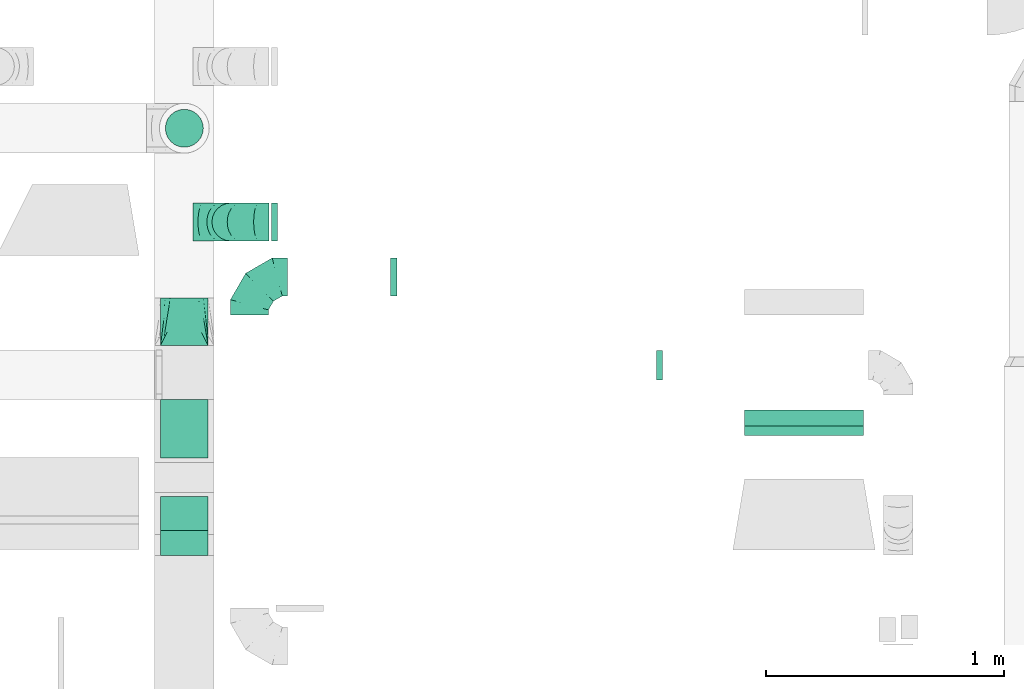
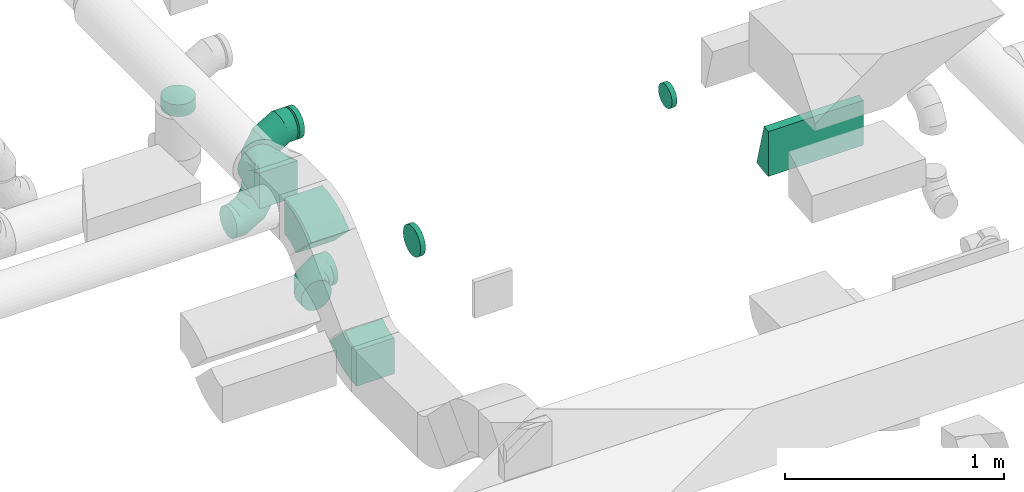
# One storey, part 42 of 62: 11 flow fittings.
"""IFC2X3 building model written with IfcOpenShell, lengths in millimetres."""

from ifc_helpers import new_model, entity, si_unit, converted_unit, derived_unit, direction, frame, frame_2d, origin, place, context, subcontext, project, spatial, polyline, circle_curve, parameter, trimmed, segment, composite_curve, outline, extrude, faceted_brep, source, transform, mapped, material, type_object, type_shapes, element, save


model = new_model("IFC2X3")

# Units and contexts
model_context = context("Model", 3, precision=0.01, world=origin(), true_north=direction((6.12303176911189e-17, 1.0)))
body_context = subcontext(model_context, "Body", "Model", "MODEL_VIEW")
ifc_project = project(units=[si_unit("LENGTHUNIT", "METRE", prefix="MILLI"), si_unit("AREAUNIT", "SQUARE_METRE"), si_unit("VOLUMEUNIT", "CUBIC_METRE"), converted_unit("PLANEANGLEUNIT", "DEGREE", entity("IfcRatioMeasure", 0.0174532925199433), si_unit("PLANEANGLEUNIT", "RADIAN"), dimensions=[0, 0, 0, 0, 0, 0, 0]), si_unit("MASSUNIT", "GRAM", prefix="KILO"), derived_unit("MASSDENSITYUNIT", [(si_unit("MASSUNIT", "GRAM", prefix="KILO"), 1), (si_unit("LENGTHUNIT", "METRE"), -3)]), derived_unit("MOMENTOFINERTIAUNIT", [(si_unit("LENGTHUNIT", "METRE"), 4)]), si_unit("TIMEUNIT", "SECOND"), si_unit("FREQUENCYUNIT", "HERTZ"), si_unit("THERMODYNAMICTEMPERATUREUNIT", "DEGREE_CELSIUS"), derived_unit("THERMALTRANSMITTANCEUNIT", [(si_unit("MASSUNIT", "GRAM", prefix="KILO"), 1), (si_unit("THERMODYNAMICTEMPERATUREUNIT", "KELVIN"), -1), (si_unit("TIMEUNIT", "SECOND"), -3)]), derived_unit("VOLUMETRICFLOWRATEUNIT", [(si_unit("LENGTHUNIT", "METRE"), 3), (si_unit("TIMEUNIT", "SECOND"), -1)]), derived_unit("MASSFLOWRATEUNIT", [(si_unit("MASSUNIT", "GRAM", prefix="KILO"), 1), (si_unit("TIMEUNIT", "SECOND"), -1)]), derived_unit("ROTATIONALFREQUENCYUNIT", [(si_unit("TIMEUNIT", "SECOND"), -1)]), si_unit("ELECTRICCURRENTUNIT", "AMPERE"), si_unit("ELECTRICVOLTAGEUNIT", "VOLT"), si_unit("POWERUNIT", "WATT"), si_unit("FORCEUNIT", "NEWTON", prefix="KILO"), si_unit("ILLUMINANCEUNIT", "LUX"), si_unit("LUMINOUSFLUXUNIT", "LUMEN"), si_unit("LUMINOUSINTENSITYUNIT", "CANDELA"), derived_unit("USERDEFINED", [(si_unit("MASSUNIT", "GRAM", prefix="KILO"), -1), (si_unit("LENGTHUNIT", "METRE"), -2), (si_unit("TIMEUNIT", "SECOND"), 3), (si_unit("LUMINOUSFLUXUNIT", "LUMEN"), 1)]), derived_unit("LINEARVELOCITYUNIT", [(si_unit("LENGTHUNIT", "METRE"), 1), (si_unit("TIMEUNIT", "SECOND"), -1)]), si_unit("PRESSUREUNIT", "PASCAL"), derived_unit("USERDEFINED", [(si_unit("LENGTHUNIT", "METRE"), -2), (si_unit("MASSUNIT", "GRAM", prefix="KILO"), 1), (si_unit("TIMEUNIT", "SECOND"), -2)]), derived_unit("LINEARFORCEUNIT", [(si_unit("MASSUNIT", "GRAM", prefix="KILO"), 1), (si_unit("LENGTHUNIT", "METRE"), 1), (si_unit("TIMEUNIT", "SECOND"), -2), (si_unit("LENGTHUNIT", "METRE"), -1)]), derived_unit("PLANARFORCEUNIT", [(si_unit("MASSUNIT", "GRAM", prefix="KILO"), 1), (si_unit("LENGTHUNIT", "METRE"), 1), (si_unit("TIMEUNIT", "SECOND"), -2), (si_unit("LENGTHUNIT", "METRE"), -2)])], contexts=[model_context])

# Site, building, storey
site_placement = place(None, origin())
site = spatial("IfcSite", under=ifc_project, at=site_placement, CompositionType="ELEMENT")
building_placement = place(site_placement, origin())
building = spatial("IfcBuilding", under=site, at=building_placement, CompositionType="ELEMENT")
storey_placement = place(building_placement, frame((0.0, 0.0, 24000.0)))
storey = spatial("IfcBuildingStorey", under=building, at=storey_placement, CompositionType="ELEMENT", Elevation=24000.0)

# Flow fittings
ifc_material = material()
duct_fitting_type_1 = type_object("IfcDuctFittingType", PredefinedType="NOTDEFINED", material=ifc_material)
shared_shape_1 = source(origin(), body_context, "Body", "Brep", [
    faceted_brep([(-160.0, 0.0, -80.0), (-160.0, -20.71, -77.27), (-160.0, -40.0, -69.28), (-160.0, -56.57, -56.57), (-160.0, -69.28, -40.0), (-160.0, -77.27, -20.71), (-160.0, -80.0, 0.0), (-160.0, -77.27, 20.71), (-160.0, -69.28, 40.0), (-160.0, -56.57, 56.57), (-160.0, -40.0, 69.28), (-160.0, -20.71, 77.27), (-160.0, 0.0, 80.0), (-160.0, 20.71, 77.27), (-160.0, 40.0, 69.28), (-160.0, 56.57, 56.57), (-160.0, 69.28, 40.0), (-160.0, 77.27, 20.71), (-160.0, 80.0, 0.0), (-160.0, 77.27, -20.71), (-160.0, 69.28, -40.0), (-160.0, 56.57, -56.57), (-160.0, 40.0, -69.28), (-160.0, 20.71, -77.27), (-122.68, 20.71, 77.27), (-127.85, 40.0, 69.28), (-117.13, 0.0, 80.0), (-132.29, 56.57, 56.57), (-137.83, 77.27, 20.71), (-138.56, 80.0, 0.0), (-135.69, 69.28, 40.0), (-135.69, 69.28, -40.0), (-132.29, 56.57, -56.57), (-137.83, 77.27, -20.71), (-122.68, 20.71, -77.27), (-117.13, 0.0, -80.0), (-127.85, 40.0, -69.28), (-111.58, -20.71, -77.27), (-106.41, -40.0, -69.28), (-101.97, -56.57, -56.57), (-98.56, -69.28, -40.0), (-96.42, -77.27, -20.71), (-95.69, -80.0, 0.0), (-96.42, -77.27, 20.71), (-98.56, -69.28, 40.0), (-101.97, -56.57, 56.57), (-106.41, -40.0, 69.28), (-111.58, -20.71, 77.27), (-58.03, 58.03, 77.27), (-72.15, 72.15, 69.28), (-42.87, 42.87, 80.0), (-84.28, 84.28, 56.57), (-93.59, 93.59, 40.0), (-99.44, 99.44, 20.71), (-101.44, 101.44, 0.0), (-99.44, 99.44, -20.71), (-93.59, 93.59, -40.0), (-84.28, 84.28, -56.57), (-58.03, 58.03, -77.27), (-42.87, 42.87, -80.0), (-72.15, 72.15, -69.28), (-27.71, 27.71, -77.27), (-13.59, 13.59, -69.28), (-1.46, 1.46, -56.57), (7.85, -7.85, -40.0), (13.7, -13.7, -20.71), (15.69, -15.69, 0.0), (13.7, -13.7, 20.71), (7.85, -7.85, 40.0), (-1.46, 1.46, 56.57), (-13.59, 13.59, 69.28), (-27.71, 27.71, 77.27), (-20.71, 122.68, 77.27), (-40.0, 127.85, 69.28), (0.0, 117.13, 80.0), (-56.57, 132.29, 56.57), (-69.28, 135.69, 40.0), (-77.27, 137.83, 20.71), (-80.0, 138.56, 0.0), (-77.27, 137.83, -20.71), (-69.28, 135.69, -40.0), (-56.57, 132.29, -56.57), (-20.71, 122.68, -77.27), (0.0, 117.13, -80.0), (-40.0, 127.85, -69.28), (20.71, 111.58, -77.27), (40.0, 106.41, -69.28), (56.57, 101.97, -56.57), (69.28, 98.56, -40.0), (77.27, 96.42, -20.71), (80.0, 95.69, 0.0), (77.27, 96.42, 20.71), (69.28, 98.56, 40.0), (56.57, 101.97, 56.57), (40.0, 106.41, 69.28), (20.71, 111.58, 77.27), (-20.71, 160.0, -77.27), (-40.0, 160.0, -69.28), (-56.57, 160.0, -56.57), (-69.28, 160.0, -40.0), (-77.27, 160.0, -20.71), (-80.0, 160.0, 0.0), (-77.27, 160.0, 20.71), (-69.28, 160.0, 40.0), (-56.57, 160.0, 56.57), (-40.0, 160.0, 69.28), (-20.71, 160.0, 77.27), (0.0, 160.0, 80.0), (20.71, 160.0, 77.27), (40.0, 160.0, 69.28), (56.57, 160.0, 56.57), (69.28, 160.0, 40.0), (77.27, 160.0, 20.71), (80.0, 160.0, 0.0), (77.27, 160.0, -20.71), (69.28, 160.0, -40.0), (56.57, 160.0, -56.57), (40.0, 160.0, -69.28), (20.71, 160.0, -77.27), (0.0, 160.0, -80.0)], [[[0, 1, 2, 3, 4, 5, 6, 7, 8, 9, 10, 11, 12, 13, 14, 15, 16, 17, 18, 19, 20, 21, 22, 23]], [[24, 25, 14, 13]], [[26, 24, 13, 12]], [[14, 25, 27, 15]], [[28, 29, 18, 17]], [[30, 28, 17, 16]], [[15, 27, 30, 16]], [[20, 31, 32, 21]], [[33, 31, 20, 19]], [[18, 29, 33, 19]], [[34, 35, 0, 23]], [[36, 34, 23, 22]], [[32, 36, 22, 21]], [[1, 0, 35, 37]], [[2, 1, 37, 38]], [[3, 2, 38, 39]], [[5, 4, 40, 41]], [[6, 5, 41, 42]], [[39, 40, 4, 3]], [[6, 42, 43, 7]], [[7, 43, 44, 8]], [[8, 44, 45, 9]], [[9, 45, 46, 10]], [[10, 46, 47, 11]], [[26, 12, 11, 47]], [[48, 49, 25, 24]], [[50, 48, 24, 26]], [[27, 25, 49, 51]], [[52, 53, 28, 30]], [[51, 52, 30, 27]], [[29, 28, 53, 54]], [[55, 56, 31, 33]], [[54, 55, 33, 29]], [[32, 31, 56, 57]], [[58, 59, 35, 34]], [[60, 58, 34, 36]], [[57, 60, 36, 32]], [[37, 35, 59, 61]], [[38, 37, 61, 62]], [[39, 38, 62, 63]], [[41, 40, 64, 65]], [[42, 41, 65, 66]], [[63, 64, 40, 39]], [[43, 42, 66, 67]], [[44, 43, 67, 68]], [[68, 69, 45, 44]], [[46, 45, 69, 70]], [[47, 46, 70, 71]], [[26, 47, 71, 50]], [[72, 73, 49, 48]], [[74, 72, 48, 50]], [[51, 49, 73, 75]], [[76, 77, 53, 52]], [[75, 76, 52, 51]], [[54, 53, 77, 78]], [[79, 80, 56, 55]], [[78, 79, 55, 54]], [[57, 56, 80, 81]], [[82, 83, 59, 58]], [[84, 82, 58, 60]], [[81, 84, 60, 57]], [[61, 59, 83, 85]], [[62, 61, 85, 86]], [[63, 62, 86, 87]], [[65, 64, 88, 89]], [[66, 65, 89, 90]], [[87, 88, 64, 63]], [[67, 66, 90, 91]], [[68, 67, 91, 92]], [[92, 93, 69, 68]], [[70, 69, 93, 94]], [[71, 70, 94, 95]], [[50, 71, 95, 74]], [[96, 97, 98, 99, 100, 101, 102, 103, 104, 105, 106, 107, 108, 109, 110, 111, 112, 113, 114, 115, 116, 117, 118, 119]], [[72, 74, 107, 106]], [[73, 72, 106, 105]], [[75, 73, 105, 104]], [[77, 76, 103, 102]], [[78, 77, 102, 101]], [[75, 104, 103, 76]], [[78, 101, 100, 79]], [[79, 100, 99, 80]], [[80, 99, 98, 81]], [[84, 97, 96, 82]], [[82, 96, 119, 83]], [[84, 81, 98, 97]], [[118, 117, 86, 85]], [[119, 118, 85, 83]], [[116, 87, 86, 117]], [[88, 115, 114, 89]], [[89, 114, 113, 90]], [[115, 88, 87, 116]], [[112, 111, 92, 91]], [[113, 112, 91, 90]], [[111, 110, 93, 92]], [[95, 94, 109, 108]], [[74, 95, 108, 107]], [[110, 109, 94, 93]]]),
])
type_shapes(duct_fitting_type_1, [shared_shape_1])
for number, where, z_axis, x_axis in (
    (1, (50952.88, 11915.19, 3114.71), (0.0, -1.0, 0.0), (1.0, 0.0, 0.0)),
    (2, (50952.88, 11915.19, 3550.0), (0.0, 1.0, 0.0), (0.0, 0.0, 1.0)),
    (3, (51030.74, 11683.83, 2860.0), (0.0, 0.0, 1.0), (-1.0, 0.0, 0.0)),
):
    element("IfcFlowFitting", number, at=place(storey_placement, frame(where, z_axis=z_axis, x_axis=x_axis)), inside=storey, type_object=duct_fitting_type_1, material=ifc_material, context=body_context, shape_type="MappedRepresentation", body=[
        mapped(shared_shape_1, transform((0.0, 0.0, 0.0), scale=1.0)),
    ])
duct_fitting_type_2 = type_object("IfcDuctFittingType", PredefinedType="NOTDEFINED", material=ifc_material)
shared_shape_2 = source(origin(), body_context, "Body", "Brep", [
    faceted_brep([(20.0, 16.18, -60.37), (20.0, 31.25, -54.13), (20.0, 44.19, -44.19), (20.0, 54.13, -31.25), (20.0, 60.37, -16.18), (20.0, 62.5, 0.0), (20.0, 60.37, 16.18), (20.0, 54.13, 31.25), (20.0, 44.19, 44.19), (20.0, 31.25, 54.13), (20.0, 16.18, 60.37), (20.0, 0.0, 62.5), (20.0, -16.18, 60.37), (20.0, -31.25, 54.13), (20.0, -44.19, 44.19), (20.0, -54.13, 31.25), (20.0, -60.37, 16.18), (20.0, -62.5, 0.0), (20.0, -60.37, -16.18), (20.0, -54.13, -31.25), (20.0, -44.19, -44.19), (20.0, -31.25, -54.13), (20.0, -16.18, -60.37), (20.0, 0.0, -62.5), (0.0, 0.0, 62.5), (0.0, 16.18, 60.37), (-6.1, 16.18, 60.37), (-6.1, 0.0, 62.5), (0.0, 31.25, 54.13), (-6.1, 31.25, 54.13), (0.0, 44.19, 44.19), (-6.1, 44.19, 44.19), (0.0, 54.13, 31.25), (0.0, 60.37, 16.18), (-6.1, 60.37, 16.18), (-6.1, 54.13, 31.25), (0.0, 62.5, 0.0), (-6.1, 62.5, 0.0), (0.0, 60.37, -16.18), (-6.1, 60.37, -16.18), (0.0, 54.13, -31.25), (-6.1, 54.13, -31.25), (0.0, 44.19, -44.19), (-6.1, 44.19, -44.19), (0.0, 31.25, -54.13), (0.0, 16.18, -60.37), (-6.1, 16.18, -60.37), (-6.1, 31.25, -54.13), (0.0, 0.0, -62.5), (-6.1, 0.0, -62.5), (0.0, -16.18, -60.37), (-6.1, -16.18, -60.37), (0.0, -31.25, -54.13), (-6.1, -31.25, -54.13), (0.0, -44.19, -44.19), (-6.1, -44.19, -44.19), (0.0, -54.13, -31.25), (0.0, -60.37, -16.18), (-6.1, -60.37, -16.18), (-6.1, -54.13, -31.25), (0.0, -62.5, 0.0), (-6.1, -62.5, 0.0), (0.0, -60.37, 16.18), (-6.1, -60.37, 16.18), (0.0, -54.13, 31.25), (-6.1, -54.13, 31.25), (0.0, -44.19, 44.19), (-6.1, -44.19, 44.19), (0.0, -31.25, 54.13), (0.0, -16.18, 60.37), (-6.1, -16.18, 60.37), (-6.1, -31.25, 54.13)], [[[0, 1, 2, 3, 4, 5, 6, 7, 8, 9, 10, 11, 12, 13, 14, 15, 16, 17, 18, 19, 20, 21, 22, 23]], [[24, 11, 10, 25, 26, 27]], [[25, 10, 9, 28, 29, 26]], [[28, 9, 8, 30, 31, 29]], [[32, 7, 6, 33, 34, 35]], [[33, 6, 5, 36, 37, 34]], [[30, 8, 7, 32, 35, 31]], [[36, 5, 4, 38, 39, 37]], [[38, 4, 3, 40, 41, 39]], [[40, 3, 2, 42, 43, 41]], [[44, 1, 0, 45, 46, 47]], [[45, 0, 23, 48, 49, 46]], [[42, 2, 1, 44, 47, 43]], [[48, 23, 22, 50, 51, 49]], [[50, 22, 21, 52, 53, 51]], [[52, 21, 20, 54, 55, 53]], [[56, 19, 18, 57, 58, 59]], [[57, 18, 17, 60, 61, 58]], [[54, 20, 19, 56, 59, 55]], [[60, 17, 16, 62, 63, 61]], [[62, 16, 15, 64, 65, 63]], [[64, 15, 14, 66, 67, 65]], [[68, 13, 12, 69, 70, 71]], [[69, 12, 11, 24, 27, 70]], [[66, 14, 13, 68, 71, 67]], [[49, 51, 53, 55, 59, 58, 61, 63, 65, 67, 71, 70, 27, 26, 29, 31, 35, 34, 37, 39, 41, 43, 47, 46]]]),
])
type_shapes(duct_fitting_type_2, [shared_shape_2])
flow_fitting_1_placement = place(storey_placement, frame((52750.03, 11312.1, 3500.0), z_axis=(0.0, -1.0, 0.0), x_axis=(1.0, 0.0, 0.0)))
element("IfcFlowFitting", 4, at=flow_fitting_1_placement, inside=storey, type_object=duct_fitting_type_2, material=ifc_material, context=body_context, shape_type="MappedRepresentation", body=[
    mapped(shared_shape_2, transform((0.0, 0.0, 0.0), scale=1.0)),
])
duct_fitting_type_3 = type_object("IfcDuctFittingType", PredefinedType="NOTDEFINED", material=ifc_material)
shared_shape_3 = source(origin(), body_context, "Body", "Brep", [
    faceted_brep([(20.0, 20.71, -77.27), (20.0, 40.0, -69.28), (20.0, 56.57, -56.57), (20.0, 69.28, -40.0), (20.0, 77.27, -20.71), (20.0, 80.0, 0.0), (20.0, 77.27, 20.71), (20.0, 69.28, 40.0), (20.0, 56.57, 56.57), (20.0, 40.0, 69.28), (20.0, 20.71, 77.27), (20.0, 0.0, 80.0), (20.0, -20.71, 77.27), (20.0, -40.0, 69.28), (20.0, -56.57, 56.57), (20.0, -69.28, 40.0), (20.0, -77.27, 20.71), (20.0, -80.0, 0.0), (20.0, -77.27, -20.71), (20.0, -69.28, -40.0), (20.0, -56.57, -56.57), (20.0, -40.0, -69.28), (20.0, -20.71, -77.27), (20.0, 0.0, -80.0), (0.0, 0.0, 80.0), (0.0, 20.71, 77.27), (-6.1, 20.71, 77.27), (-6.1, 0.0, 80.0), (0.0, 40.0, 69.28), (-6.1, 40.0, 69.28), (0.0, 56.57, 56.57), (-6.1, 56.57, 56.57), (0.0, 69.28, 40.0), (0.0, 77.27, 20.71), (-6.1, 77.27, 20.71), (-6.1, 69.28, 40.0), (0.0, 80.0, 0.0), (-6.1, 80.0, 0.0), (0.0, 77.27, -20.71), (-6.1, 77.27, -20.71), (0.0, 69.28, -40.0), (-6.1, 69.28, -40.0), (0.0, 56.57, -56.57), (-6.1, 56.57, -56.57), (0.0, 40.0, -69.28), (0.0, 20.71, -77.27), (-6.1, 20.71, -77.27), (-6.1, 40.0, -69.28), (0.0, 0.0, -80.0), (-6.1, 0.0, -80.0), (0.0, -20.71, -77.27), (-6.1, -20.71, -77.27), (0.0, -40.0, -69.28), (-6.1, -40.0, -69.28), (0.0, -56.57, -56.57), (-6.1, -56.57, -56.57), (0.0, -69.28, -40.0), (0.0, -77.27, -20.71), (-6.1, -77.27, -20.71), (-6.1, -69.28, -40.0), (0.0, -80.0, 0.0), (-6.1, -80.0, 0.0), (0.0, -77.27, 20.71), (-6.1, -77.27, 20.71), (0.0, -69.28, 40.0), (-6.1, -69.28, 40.0), (0.0, -56.57, 56.57), (-6.1, -56.57, 56.57), (0.0, -40.0, 69.28), (0.0, -20.71, 77.27), (-6.1, -20.71, 77.27), (-6.1, -40.0, 69.28)], [[[0, 1, 2, 3, 4, 5, 6, 7, 8, 9, 10, 11, 12, 13, 14, 15, 16, 17, 18, 19, 20, 21, 22, 23]], [[24, 11, 10, 25, 26, 27]], [[25, 10, 9, 28, 29, 26]], [[28, 9, 8, 30, 31, 29]], [[32, 7, 6, 33, 34, 35]], [[33, 6, 5, 36, 37, 34]], [[30, 8, 7, 32, 35, 31]], [[36, 5, 4, 38, 39, 37]], [[38, 4, 3, 40, 41, 39]], [[40, 3, 2, 42, 43, 41]], [[44, 1, 0, 45, 46, 47]], [[45, 0, 23, 48, 49, 46]], [[42, 2, 1, 44, 47, 43]], [[48, 23, 22, 50, 51, 49]], [[50, 22, 21, 52, 53, 51]], [[52, 21, 20, 54, 55, 53]], [[56, 19, 18, 57, 58, 59]], [[57, 18, 17, 60, 61, 58]], [[54, 20, 19, 56, 59, 55]], [[60, 17, 16, 62, 63, 61]], [[62, 16, 15, 64, 65, 63]], [[64, 15, 14, 66, 67, 65]], [[68, 13, 12, 69, 70, 71]], [[69, 12, 11, 24, 27, 70]], [[66, 14, 13, 68, 71, 67]], [[49, 51, 53, 55, 59, 58, 61, 63, 65, 67, 71, 70, 27, 26, 29, 31, 35, 34, 37, 39, 41, 43, 47, 46]]]),
])
type_shapes(duct_fitting_type_3, [shared_shape_3])
for number, where, z_axis, x_axis in (
    (5, (51645.21, 11683.83, 2860.0), (0.0, 1.0, 0.0), (-1.0, 0.0, 0.0)),
    (6, (51142.9, 11915.19, 3550.0), (0.0, 0.0, -1.0), (-1.0, 0.0, 0.0)),
):
    element("IfcFlowFitting", number, at=place(storey_placement, frame(where, z_axis=z_axis, x_axis=x_axis)), inside=storey, type_object=duct_fitting_type_3, material=ifc_material, context=body_context, shape_type="MappedRepresentation", body=[
        mapped(shared_shape_3, transform((0.0, 0.0, 0.0), scale=1.0)),
    ])
duct_fitting_type_4 = type_object("IfcDuctFittingType", PredefinedType="NOTDEFINED", material=ifc_material)
shared_shape_4 = source(origin(), body_context, "Body", "Brep", [
    faceted_brep([(20.0, 20.71, -77.27), (20.0, 40.0, -69.28), (20.0, 56.57, -56.57), (20.0, 69.28, -40.0), (20.0, 77.27, -20.71), (20.0, 80.0, 0.0), (20.0, 77.27, 20.71), (20.0, 69.28, 40.0), (20.0, 56.57, 56.57), (20.0, 40.0, 69.28), (20.0, 20.71, 77.27), (20.0, 0.0, 80.0), (20.0, -20.71, 77.27), (20.0, -40.0, 69.28), (20.0, -56.57, 56.57), (20.0, -69.28, 40.0), (20.0, -77.27, 20.71), (20.0, -80.0, 0.0), (20.0, -77.27, -20.71), (20.0, -69.28, -40.0), (20.0, -56.57, -56.57), (20.0, -40.0, -69.28), (20.0, -20.71, -77.27), (20.0, 0.0, -80.0), (0.0, 0.0, 80.0), (0.0, 20.71, 77.27), (-46.1, 20.71, 77.27), (-46.1, 0.0, 80.0), (0.0, 40.0, 69.28), (-46.1, 40.0, 69.28), (0.0, 56.57, 56.57), (-46.1, 56.57, 56.57), (0.0, 69.28, 40.0), (0.0, 77.27, 20.71), (-46.1, 77.27, 20.71), (-46.1, 69.28, 40.0), (0.0, 80.0, 0.0), (-46.1, 80.0, 0.0), (0.0, 77.27, -20.71), (-46.1, 77.27, -20.71), (0.0, 69.28, -40.0), (-46.1, 69.28, -40.0), (0.0, 56.57, -56.57), (-46.1, 56.57, -56.57), (0.0, 40.0, -69.28), (0.0, 20.71, -77.27), (-46.1, 20.71, -77.27), (-46.1, 40.0, -69.28), (0.0, 0.0, -80.0), (-46.1, 0.0, -80.0), (0.0, -20.71, -77.27), (-46.1, -20.71, -77.27), (0.0, -40.0, -69.28), (-46.1, -40.0, -69.28), (0.0, -56.57, -56.57), (-46.1, -56.57, -56.57), (0.0, -69.28, -40.0), (0.0, -77.27, -20.71), (-46.1, -77.27, -20.71), (-46.1, -69.28, -40.0), (0.0, -80.0, 0.0), (-46.1, -80.0, 0.0), (0.0, -77.27, 20.71), (-46.1, -77.27, 20.71), (0.0, -69.28, 40.0), (-46.1, -69.28, 40.0), (0.0, -56.57, 56.57), (-46.1, -56.57, 56.57), (0.0, -40.0, 69.28), (0.0, -20.71, 77.27), (-46.1, -20.71, 77.27), (-46.1, -40.0, 69.28)], [[[0, 1, 2, 3, 4, 5, 6, 7, 8, 9, 10, 11, 12, 13, 14, 15, 16, 17, 18, 19, 20, 21, 22, 23]], [[24, 11, 10, 25, 26, 27]], [[25, 10, 9, 28, 29, 26]], [[28, 9, 8, 30, 31, 29]], [[32, 7, 6, 33, 34, 35]], [[33, 6, 5, 36, 37, 34]], [[30, 8, 7, 32, 35, 31]], [[36, 5, 4, 38, 39, 37]], [[38, 4, 3, 40, 41, 39]], [[40, 3, 2, 42, 43, 41]], [[44, 1, 0, 45, 46, 47]], [[45, 0, 23, 48, 49, 46]], [[42, 2, 1, 44, 47, 43]], [[48, 23, 22, 50, 51, 49]], [[50, 22, 21, 52, 53, 51]], [[52, 21, 20, 54, 55, 53]], [[56, 19, 18, 57, 58, 59]], [[57, 18, 17, 60, 61, 58]], [[54, 20, 19, 56, 59, 55]], [[60, 17, 16, 62, 63, 61]], [[62, 16, 15, 64, 65, 63]], [[64, 15, 14, 66, 67, 65]], [[68, 13, 12, 69, 70, 71]], [[69, 12, 11, 24, 27, 70]], [[66, 14, 13, 68, 71, 67]], [[49, 51, 53, 55, 59, 58, 61, 63, 65, 67, 71, 70, 27, 26, 29, 31, 35, 34, 37, 39, 41, 43, 47, 46]]]),
])
type_shapes(duct_fitting_type_4, [shared_shape_4])
flow_fitting_2_placement = place(storey_placement, frame((50756.62, 12310.04, 3550.0), z_axis=(-1.0, 0.0, 0.0), x_axis=(0.0, 0.0, -1.0)))
element("IfcFlowFitting", 7, at=flow_fitting_2_placement, inside=storey, type_object=duct_fitting_type_4, material=ifc_material, context=body_context, shape_type="MappedRepresentation", body=[
    mapped(shared_shape_4, transform((0.0, 0.0, 0.0), scale=1.0)),
])
duct_fitting_type_5 = type_object("IfcDuctFittingType", PredefinedType="NOTDEFINED", material=ifc_material)
shared_shape_5 = source(origin(), body_context, "Body", "Brep", [
    faceted_brep([(200.0, 30.9, 95.11), (200.0, 19.08, 96.98), (200.0, 9.54, 98.49), (200.0, 4.77, 99.24), (200.0, 0.0, 100.0), (200.0, -4.77, 99.24), (200.0, -9.54, 98.49), (200.0, -19.08, 96.98), (200.0, -30.9, 95.11), (200.0, -44.84, 88.0), (200.0, -58.78, 80.9), (200.0, -69.84, 69.84), (200.0, -80.9, 58.78), (200.0, -88.0, 44.84), (200.0, -95.11, 30.9), (200.0, -96.98, 19.08), (200.0, -98.49, 9.54), (200.0, -99.24, 4.77), (200.0, -100.0, 0.0), (200.0, -99.24, -4.77), (200.0, -98.49, -9.54), (200.0, -96.98, -19.08), (200.0, -95.11, -30.9), (200.0, -88.0, -44.84), (200.0, -80.9, -58.78), (200.0, -69.84, -69.84), (200.0, -58.78, -80.9), (200.0, -44.84, -88.0), (200.0, -30.9, -95.11), (200.0, -19.08, -96.98), (200.0, -9.54, -98.49), (200.0, -4.77, -99.24), (200.0, 0.0, -100.0), (200.0, 4.77, -99.24), (200.0, 9.54, -98.49), (200.0, 19.08, -96.98), (200.0, 30.9, -95.11), (200.0, 44.84, -88.0), (200.0, 58.78, -80.9), (200.0, 69.84, -69.84), (200.0, 80.9, -58.78), (200.0, 88.0, -44.84), (200.0, 95.11, -30.9), (200.0, 96.98, -19.08), (200.0, 98.49, -9.54), (200.0, 99.24, -4.77), (200.0, 100.0, 0.0), (200.0, 99.24, 4.77), (200.0, 98.49, 9.54), (200.0, 96.98, 19.08), (200.0, 95.11, 30.9), (200.0, 88.0, 44.84), (200.0, 80.9, 58.78), (200.0, 69.84, 69.84), (200.0, 58.78, 80.9), (200.0, 44.84, 88.0), (0.0, -100.0, 100.0), (0.0, 100.0, 100.0), (0.0, 100.0, -100.0), (0.0, -100.0, -100.0), (104.11, -47.94, 100.0), (100.0, -83.15, 87.43), (26.03, -86.99, 100.0), (78.09, -60.96, 100.0), (52.06, -73.97, 100.0), (188.01, -5.99, 100.0), (176.03, -11.99, 100.0), (152.06, -23.97, 100.0), (128.09, -35.96, 100.0), (52.06, -100.0, 73.97), (78.09, -100.0, 60.96), (104.11, -100.0, 47.94), (128.09, -100.0, 35.96), (152.06, -100.0, 23.97), (176.03, -100.0, 11.99), (188.01, -100.0, 5.99), (26.03, -100.0, 86.99), (26.03, -100.0, -86.99), (52.06, -100.0, -73.97), (78.09, -100.0, -60.96), (104.11, -100.0, -47.94), (128.09, -100.0, -35.96), (152.06, -100.0, -23.97), (176.03, -100.0, -11.99), (188.01, -100.0, -5.99), (100.0, -87.43, -83.15), (52.06, -73.97, -100.0), (78.09, -60.96, -100.0), (104.11, -47.94, -100.0), (128.09, -35.96, -100.0), (152.06, -23.97, -100.0), (176.03, -11.99, -100.0), (188.01, -5.99, -100.0), (26.03, -86.99, -100.0), (26.03, 86.99, -100.0), (52.06, 73.97, -100.0), (78.09, 60.96, -100.0), (104.11, 47.94, -100.0), (128.09, 35.96, -100.0), (152.06, 23.97, -100.0), (176.03, 11.99, -100.0), (188.01, 5.99, -100.0), (100.0, 83.15, -87.43), (52.06, 100.0, -73.97), (78.09, 100.0, -60.96), (104.11, 100.0, -47.94), (128.09, 100.0, -35.96), (152.06, 100.0, -23.97), (176.03, 100.0, -11.99), (188.01, 100.0, -5.99), (26.03, 100.0, -86.99), (26.03, 100.0, 86.99), (52.06, 100.0, 73.97), (78.09, 100.0, 60.96), (104.11, 100.0, 47.94), (128.09, 100.0, 35.96), (152.06, 100.0, 23.97), (176.03, 100.0, 11.99), (188.01, 100.0, 5.99), (100.0, 87.43, 83.15), (52.06, 73.97, 100.0), (78.09, 60.96, 100.0), (104.11, 47.94, 100.0), (128.09, 35.96, 100.0), (152.06, 23.97, 100.0), (176.03, 11.99, 100.0), (188.01, 5.99, 100.0), (26.03, 86.99, 100.0)], [[[0, 1, 2, 3, 4, 5, 6, 7, 8, 9, 10, 11, 12, 13, 14, 15, 16, 17, 18, 19, 20, 21, 22, 23, 24, 25, 26, 27, 28, 29, 30, 31, 32, 33, 34, 35, 36, 37, 38, 39, 40, 41, 42, 43, 44, 45, 46, 47, 48, 49, 50, 51, 52, 53, 54, 55]], [[56, 57, 58, 59]], [[60, 9, 8]], [[56, 61, 62]], [[9, 60, 63, 64]], [[65, 66, 67, 68, 60, 8, 7, 6, 5, 4]], [[62, 61, 10]], [[13, 69, 70, 71]], [[64, 10, 9]], [[14, 71, 72, 73, 74, 75, 18, 17, 16, 15]], [[12, 76, 69]], [[71, 14, 13]], [[61, 76, 11]], [[10, 64, 62]], [[76, 12, 11]], [[10, 61, 11]], [[61, 56, 76]], [[69, 13, 12]], [[75, 74, 73, 72, 71, 70, 69, 76, 56, 59, 77, 78, 79, 80, 81, 82, 83, 84, 18]], [[80, 23, 22]], [[59, 85, 77]], [[23, 80, 79, 78]], [[84, 83, 82, 81, 80, 22, 21, 20, 19, 18]], [[77, 85, 24]], [[27, 86, 87, 88]], [[78, 24, 23]], [[28, 88, 89, 90, 91, 92, 32, 31, 30, 29]], [[26, 93, 86]], [[88, 28, 27]], [[85, 93, 25]], [[24, 78, 77]], [[93, 26, 25]], [[24, 85, 25]], [[85, 59, 93]], [[86, 27, 26]], [[92, 91, 90, 89, 88, 87, 86, 93, 59, 58, 94, 95, 96, 97, 98, 99, 100, 101, 32]], [[97, 37, 36]], [[58, 102, 94]], [[37, 97, 96, 95]], [[101, 100, 99, 98, 97, 36, 35, 34, 33, 32]], [[94, 102, 38]], [[41, 103, 104, 105]], [[95, 38, 37]], [[42, 105, 106, 107, 108, 109, 46, 45, 44, 43]], [[40, 110, 103]], [[105, 42, 41]], [[102, 110, 39]], [[38, 95, 94]], [[110, 40, 39]], [[38, 102, 39]], [[102, 58, 110]], [[103, 41, 40]], [[58, 57, 111, 112, 113, 114, 115, 116, 117, 118, 46, 109, 108, 107, 106, 105, 104, 103, 110]], [[114, 51, 50]], [[57, 119, 111]], [[51, 114, 113, 112]], [[118, 117, 116, 115, 114, 50, 49, 48, 47, 46]], [[111, 119, 52]], [[55, 120, 121, 122]], [[112, 52, 51]], [[0, 122, 123, 124, 125, 126, 4, 3, 2, 1]], [[54, 127, 120]], [[122, 0, 55]], [[119, 127, 53]], [[52, 112, 111]], [[127, 54, 53]], [[52, 119, 53]], [[119, 57, 127]], [[120, 55, 54]], [[57, 56, 62, 64, 63, 60, 68, 67, 66, 65, 4, 126, 125, 124, 123, 122, 121, 120, 127]]]),
])
type_shapes(duct_fitting_type_5, [shared_shape_5])
flow_fitting_3_placement = place(storey_placement, frame((50756.62, 11395.58, 3650.0), z_axis=(0.0, 0.0, 1.0), x_axis=(0.0, 1.0, 0.0)))
element("IfcFlowFitting", 8, at=flow_fitting_3_placement, inside=storey, type_object=duct_fitting_type_5, material=ifc_material, context=body_context, shape_type="MappedRepresentation", body=[
    mapped(shared_shape_5, transform((0.0, 0.0, 0.0), scale=1.0)),
])
duct_fitting_type_6 = type_object("IfcDuctFittingType", PredefinedType="NOTDEFINED", material=ifc_material)
shared_shape_6 = source(origin(), body_context, "Body", "SweptSolid", [
    extrude(outline(composite_curve([segment(polyline([(-136.61, -88.39), (63.39, -88.39)]), True, "CONTINUOUS"), segment(trimmed(circle_curve(frame_2d((213.39, -88.39), x_axis=(-0.707106781186546, 0.707106781186546)), 150.0), [parameter(0.0)], [parameter(45.0)], True, "PARAMETER"), False, "CONTINUOUS"), segment(polyline([(107.32, 17.68), (-34.1, 159.1)]), True, "CONTINUOUS"), segment(trimmed(circle_curve(frame_2d((213.39, -88.39), x_axis=(-0.707106781186546, 0.707106781186546)), 350.0), [parameter(0.0)], [parameter(45.0)], True, "PARAMETER"), True, "CONTINUOUS")], self_intersect=False)), frame((-15.17, 36.61, -100.0), z_axis=(0.0, 0.0, 1.0), x_axis=(-0.707106781186547, 0.707106781186548, 0.0)), (0.0, 0.0, 1.0), 200.0),
])
type_shapes(duct_fitting_type_6, [shared_shape_6])
for number, where, z_axis, x_axis in (
    (9, (50756.62, 11064.9, 3650.0), (1.0, 0.0, 0.0), (0.0, -1.0, 0.0)),
    (10, (50756.62, 10614.9, 3200.0), (-1.0, 0.0, 0.0), (0.0, -0.70710678118652, -0.707106781186575)),
):
    element("IfcFlowFitting", number, at=place(storey_placement, frame(where, z_axis=z_axis, x_axis=x_axis)), inside=storey, type_object=duct_fitting_type_6, material=ifc_material, context=body_context, shape_type="MappedRepresentation", body=[
        mapped(shared_shape_6, transform((0.0, 0.0, 0.0), scale=1.0)),
    ])
duct_fitting_type_7 = type_object("IfcDuctFittingType", PredefinedType="NOTDEFINED", material=ifc_material)
shared_shape_7 = source(origin(), body_context, "Body", "SweptSolid", [
    extrude(outline(composite_curve([segment(polyline([(-130.02, -36.82), (119.98, -36.82)]), True, "CONTINUOUS"), segment(trimmed(circle_curve(frame_2d((269.98, -36.82), x_axis=(-0.963480255930653, 0.267779380146798)), 150.0), [parameter(0.0)], [parameter(15.5321696608975)], True, "PARAMETER"), False, "CONTINUOUS"), segment(polyline([(125.46, 3.35), (-115.41, 70.29)]), True, "CONTINUOUS"), segment(trimmed(circle_curve(frame_2d((269.98, -36.82), x_axis=(-0.963480255930653, 0.267779380146798)), 400.0), [parameter(0.0)], [parameter(15.5321696608975)], True, "PARAMETER"), True, "CONTINUOUS")], self_intersect=False)), frame((-0.68, 5.02, -250.0), z_axis=(0.0, 0.0, 1.0), x_axis=(-0.267779380146797, 0.963480255930653, 0.0)), (0.0, 0.0, 1.0), 500.0),
])
type_shapes(duct_fitting_type_7, [shared_shape_7])
flow_fitting_4_placement = place(storey_placement, frame((53365.82, 11053.33, 3225.0), z_axis=(1.0, 0.0, 0.0), x_axis=(0.0, 1.0, 0.0)))
element("IfcFlowFitting", 11, at=flow_fitting_4_placement, inside=storey, type_object=duct_fitting_type_7, material=ifc_material, context=body_context, shape_type="MappedRepresentation", body=[
    mapped(shared_shape_7, transform((0.0, 0.0, 0.0), scale=1.0)),
])

save(model, "model.ifc")
